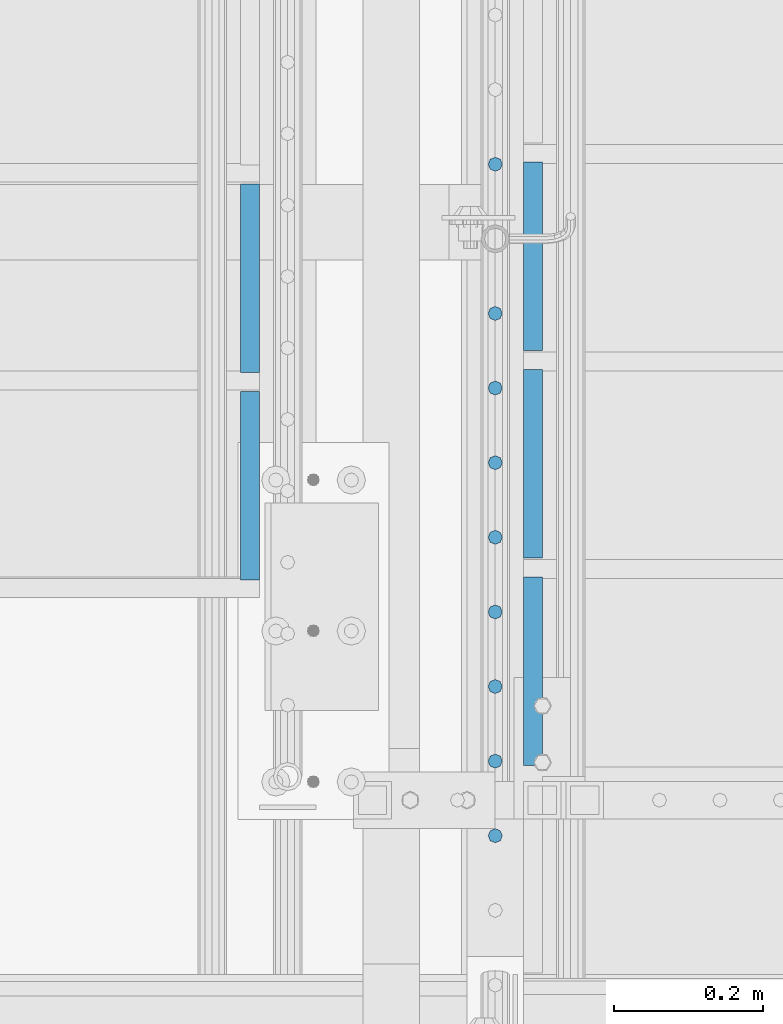
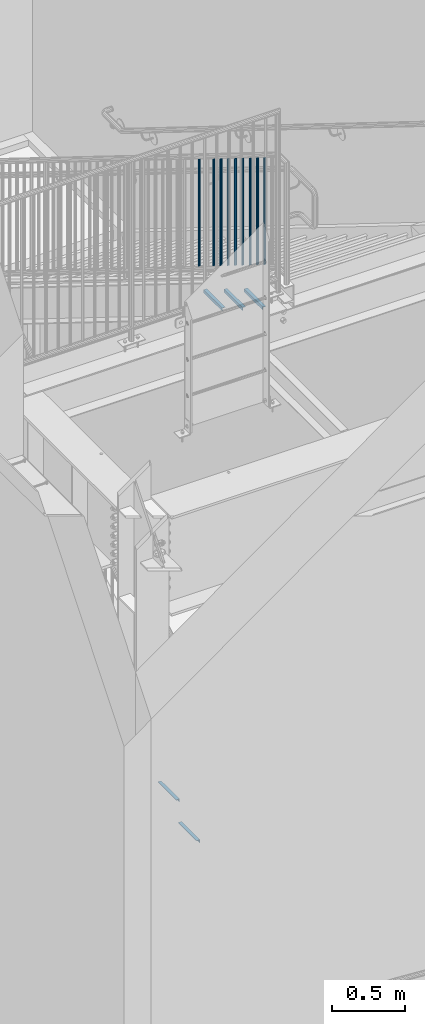
# One storey, part 1262 of 1763: 14 beams, 3 elements without a shape of their own.
"""IFC2X3 building model written with IfcOpenShell, lengths in millimetres."""

from ifc_helpers import new_model, si_unit, frame, origin_with_axes, place, context, subcontext, project, spatial, faceted_brep, material, type_object, element, aggregate, save


model = new_model("IFC2X3")

# Units and contexts
model_context = context("Model", 3, precision=1e-05, world=origin_with_axes())
body_context = subcontext(model_context, "Body", "Model", "MODEL_VIEW")
ifc_project = project(units=[si_unit("LENGTHUNIT", "METRE", prefix="MILLI"), si_unit("AREAUNIT", "SQUARE_METRE"), si_unit("VOLUMEUNIT", "CUBIC_METRE"), si_unit("MASSUNIT", "GRAM", prefix="KILO"), si_unit("TIMEUNIT", "SECOND"), si_unit("PLANEANGLEUNIT", "RADIAN"), si_unit("SOLIDANGLEUNIT", "STERADIAN"), si_unit("THERMODYNAMICTEMPERATUREUNIT", "DEGREE_CELSIUS"), si_unit("LUMINOUSINTENSITYUNIT", "LUMEN")], contexts=[model_context])

# Site, building, storey
site_placement = place(None, origin_with_axes())
site = spatial("IfcSite", under=ifc_project, at=site_placement, CompositionType="ELEMENT")
building_placement = place(site_placement, origin_with_axes())
building = spatial("IfcBuilding", under=site, at=building_placement, Name="Undefined", CompositionType="ELEMENT")
storey_placement = place(building_placement, origin_with_axes())
storey = spatial("IfcBuildingStorey", under=building, at=storey_placement, Name="Undefined", CompositionType="ELEMENT", Elevation=0.0)

# Assembly, beams
assembly_1_placement = place(storey_placement, origin_with_axes())
assembly_1 = element("IfcElementAssembly", 1, at=assembly_1_placement, inside=storey, Name="RAIL", AssemblyPlace="NOTDEFINED", PredefinedType="RIGID_FRAME")
ifc_material = material(Name="STEEL/A36")
beam_type_1 = type_object("IfcBeamType", PredefinedType="NOTDEFINED")
beam_1_placement = place(assembly_1_placement, frame((-85279.8721005486, 31975.1363633052, 6284.68158989683), z_axis=(1.0, 0.0, 0.0), x_axis=(0.0, 0.0, -1.0)))
beam_1 = element("IfcBeam", 2, at=beam_1_placement, type_object=beam_type_1, material=ifc_material, Name="PICKET", context=body_context, shape_type="Brep", body=[
    faceted_brep([(16.5092624764411, -9.52500000000146, 0.0), (18.2412682186596, -6.73519209080041, -6.73519209079677), (919.54586829654, -6.73519209080041, -6.73519209079677), (917.813862554322, -9.52500000000146, 0.0), (22.4226999716293, 0.0, -9.52499999999418), (923.727300049511, 0.0, -9.52499999999418), (26.6041317245999, 6.73519209080041, -6.73519209079677), (927.908731802481, 6.73519209080041, -6.73519209079677), (28.3361374668184, 9.52500000000146, 0.0), (929.6407375447, 9.52500000000146, 0.0), (26.6041317245999, 6.73519209080041, 6.73519209079677), (927.908731802481, 6.73519209080041, 6.73519209079677), (22.4226999716293, 0.0, 9.52499999999418), (923.727300049511, 0.0, 9.52499999999418), (18.2412682186596, -6.73519209080041, 6.73519209079677), (919.54586829654, -6.73519209080041, 6.73519209079677)], [[[0, 1, 2, 3]], [[1, 4, 5, 2]], [[4, 6, 7, 5]], [[6, 8, 9, 7]], [[8, 10, 11, 9]], [[10, 12, 13, 11]], [[12, 14, 15, 13]], [[14, 0, 3, 15]], [[5, 7, 9, 11, 13, 15, 3, 2]], [[14, 12, 10, 8, 6, 4, 1, 0]]]),
])
beam_2_placement = place(assembly_1_placement, frame((-85279.8721005486, 32075.5818178678, 6222.32170357328), z_axis=(1.0, 0.0, 0.0), x_axis=(0.0, 0.0, -1.0)))
beam_2 = element("IfcBeam", 3, at=beam_2_placement, type_object=beam_type_1, material=ifc_material, Name="PICKET", context=body_context, shape_type="Brep", body=[
    faceted_brep([(16.5092624764411, -9.52500000000146, 0.0), (18.2412682186596, -6.73519209080041, -6.73519209079677), (919.54586829654, -6.73519209080041, -6.73519209079677), (917.813862554322, -9.52500000000146, 0.0), (22.4226999716293, 0.0, -9.52499999999418), (923.727300049511, 0.0, -9.52499999999418), (26.6041317245999, 6.73519209080041, -6.73519209079677), (927.908731802481, 6.73519209080041, -6.73519209079677), (28.3361374668184, 9.52500000000146, 0.0), (929.6407375447, 9.52500000000146, 0.0), (26.6041317245999, 6.73519209080041, 6.73519209079677), (927.908731802481, 6.73519209080041, 6.73519209079677), (22.4226999716293, 0.0, 9.52499999999418), (923.727300049511, 0.0, 9.52499999999418), (18.2412682186596, -6.73519209080041, 6.73519209079677), (919.54586829654, -6.73519209080041, 6.73519209079677)], [[[0, 1, 2, 3]], [[1, 4, 5, 2]], [[4, 6, 7, 5]], [[6, 8, 9, 7]], [[8, 10, 11, 9]], [[10, 12, 13, 11]], [[12, 14, 15, 13]], [[14, 0, 3, 15]], [[5, 7, 9, 11, 13, 15, 3, 2]], [[14, 12, 10, 8, 6, 4, 1, 0]]]),
])
beam_3_placement = place(assembly_1_placement, frame((-85279.8721005486, 32176.0272724304, 6159.96181724973), z_axis=(1.0, 0.0, 0.0), x_axis=(0.0, 0.0, -1.0)))
beam_3 = element("IfcBeam", 4, at=beam_3_placement, type_object=beam_type_1, material=ifc_material, Name="PICKET", context=body_context, shape_type="Brep", body=[
    faceted_brep([(16.5092624764411, -9.52500000000146, 0.0), (18.2412682186596, -6.73519209080041, -6.73519209079677), (919.54586829654, -6.73519209080041, -6.73519209079677), (917.813862554322, -9.52500000000146, 0.0), (22.4226999716293, 0.0, -9.52499999999418), (923.727300049511, 0.0, -9.52499999999418), (26.6041317245999, 6.73519209080041, -6.73519209079677), (927.908731802481, 6.73519209080041, -6.73519209079677), (28.3361374668184, 9.52500000000146, 0.0), (929.6407375447, 9.52500000000146, 0.0), (26.6041317245999, 6.73519209080041, 6.73519209079677), (927.908731802481, 6.73519209080041, 6.73519209079677), (22.4226999716293, 0.0, 9.52499999999418), (923.727300049511, 0.0, 9.52499999999418), (18.2412682186596, -6.73519209080041, 6.73519209079677), (919.54586829654, -6.73519209080041, 6.73519209079677)], [[[0, 1, 2, 3]], [[1, 4, 5, 2]], [[4, 6, 7, 5]], [[6, 8, 9, 7]], [[8, 10, 11, 9]], [[10, 12, 13, 11]], [[12, 14, 15, 13]], [[14, 0, 3, 15]], [[5, 7, 9, 11, 13, 15, 3, 2]], [[14, 12, 10, 8, 6, 4, 1, 0]]]),
])
beam_4_placement = place(assembly_1_placement, frame((-85279.8721005486, 32276.4727269931, 6097.60193092619), z_axis=(1.0, 0.0, 0.0), x_axis=(0.0, 0.0, -1.0)))
beam_4 = element("IfcBeam", 5, at=beam_4_placement, type_object=beam_type_1, material=ifc_material, Name="PICKET", context=body_context, shape_type="Brep", body=[
    faceted_brep([(16.5092624764411, -9.52500000000146, 0.0), (18.2412682186596, -6.73519209080041, -6.73519209079677), (919.54586829654, -6.73519209080041, -6.73519209079677), (917.813862554322, -9.52500000000146, 0.0), (22.4226999716293, 0.0, -9.52499999999418), (923.727300049511, 0.0, -9.52499999999418), (26.6041317245999, 6.73519209080041, -6.73519209079677), (927.908731802481, 6.73519209080041, -6.73519209079677), (28.3361374668184, 9.52500000000146, 0.0), (929.6407375447, 9.52500000000146, 0.0), (26.6041317245999, 6.73519209080041, 6.73519209079677), (927.908731802481, 6.73519209080041, 6.73519209079677), (22.4226999716293, 0.0, 9.52499999999418), (923.727300049511, 0.0, 9.52499999999418), (18.2412682186596, -6.73519209080041, 6.73519209079677), (919.54586829654, -6.73519209080041, 6.73519209079677)], [[[0, 1, 2, 3]], [[1, 4, 5, 2]], [[4, 6, 7, 5]], [[6, 8, 9, 7]], [[8, 10, 11, 9]], [[10, 12, 13, 11]], [[12, 14, 15, 13]], [[14, 0, 3, 15]], [[5, 7, 9, 11, 13, 15, 3, 2]], [[14, 12, 10, 8, 6, 4, 1, 0]]]),
])
beam_5_placement = place(assembly_1_placement, frame((-85279.8721005486, 32376.9181815557, 6035.24204460264), z_axis=(1.0, 0.0, 0.0), x_axis=(0.0, 0.0, -1.0)))
beam_5 = element("IfcBeam", 6, at=beam_5_placement, type_object=beam_type_1, material=ifc_material, Name="PICKET", context=body_context, shape_type="Brep", body=[
    faceted_brep([(16.5092624764411, -9.52500000000146, 0.0), (18.2412682186596, -6.73519209080041, -6.73519209079677), (919.54586829654, -6.73519209080041, -6.73519209079677), (917.813862554322, -9.52500000000146, 0.0), (22.4226999716293, 0.0, -9.52499999999418), (923.727300049511, 0.0, -9.52499999999418), (26.6041317245999, 6.73519209080041, -6.73519209079677), (927.908731802481, 6.73519209080041, -6.73519209079677), (28.3361374668184, 9.52500000000146, 0.0), (929.6407375447, 9.52500000000146, 0.0), (26.6041317245999, 6.73519209080041, 6.73519209079677), (927.908731802481, 6.73519209080041, 6.73519209079677), (22.4226999716293, 0.0, 9.52499999999418), (923.727300049511, 0.0, 9.52499999999418), (18.2412682186596, -6.73519209080041, 6.73519209079677), (919.54586829654, -6.73519209080041, 6.73519209079677)], [[[0, 1, 2, 3]], [[1, 4, 5, 2]], [[4, 6, 7, 5]], [[6, 8, 9, 7]], [[8, 10, 11, 9]], [[10, 12, 13, 11]], [[12, 14, 15, 13]], [[14, 0, 3, 15]], [[5, 7, 9, 11, 13, 15, 3, 2]], [[14, 12, 10, 8, 6, 4, 1, 0]]]),
])
beam_6_placement = place(assembly_1_placement, frame((-85279.8721005486, 32477.3636361183, 5972.88215827909), z_axis=(1.0, 0.0, 0.0), x_axis=(0.0, 0.0, -1.0)))
beam_6 = element("IfcBeam", 7, at=beam_6_placement, type_object=beam_type_1, material=ifc_material, Name="PICKET", context=body_context, shape_type="Brep", body=[
    faceted_brep([(16.5092624764411, -9.52500000000146, 0.0), (18.2412682186596, -6.73519209080041, -6.73519209079677), (919.54586829654, -6.73519209080041, -6.73519209079677), (917.813862554322, -9.52500000000146, 0.0), (22.4226999716293, 0.0, -9.52499999999418), (923.727300049511, 0.0, -9.52499999999418), (26.6041317245999, 6.73519209080041, -6.73519209079677), (927.908731802481, 6.73519209080041, -6.73519209079677), (28.3361374668184, 9.52500000000146, 0.0), (929.6407375447, 9.52500000000146, 0.0), (26.6041317245999, 6.73519209080041, 6.73519209079677), (927.908731802481, 6.73519209080041, 6.73519209079677), (22.4226999716293, 0.0, 9.52499999999418), (923.727300049511, 0.0, 9.52499999999418), (18.2412682186596, -6.73519209080041, 6.73519209079677), (919.54586829654, -6.73519209080041, 6.73519209079677)], [[[0, 1, 2, 3]], [[1, 4, 5, 2]], [[4, 6, 7, 5]], [[6, 8, 9, 7]], [[8, 10, 11, 9]], [[10, 12, 13, 11]], [[12, 14, 15, 13]], [[14, 0, 3, 15]], [[5, 7, 9, 11, 13, 15, 3, 2]], [[14, 12, 10, 8, 6, 4, 1, 0]]]),
])
beam_7_placement = place(assembly_1_placement, frame((-85279.8721005486, 32577.8090906809, 5910.52227195554), z_axis=(1.0, 0.0, 0.0), x_axis=(0.0, 0.0, -1.0)))
beam_7 = element("IfcBeam", 8, at=beam_7_placement, type_object=beam_type_1, material=ifc_material, Name="PICKET", context=body_context, shape_type="Brep", body=[
    faceted_brep([(16.5092624764411, -9.52500000000146, 0.0), (18.2412682186596, -6.73519209080041, -6.73519209079677), (919.54586829654, -6.73519209080041, -6.73519209079677), (917.813862554322, -9.52500000000146, 0.0), (22.4226999716293, 0.0, -9.52499999999418), (923.727300049511, 0.0, -9.52499999999418), (26.6041317245999, 6.73519209080041, -6.73519209079677), (927.908731802481, 6.73519209080041, -6.73519209079677), (28.3361374668184, 9.52500000000146, 0.0), (929.6407375447, 9.52500000000146, 0.0), (26.6041317245999, 6.73519209080041, 6.73519209079677), (927.908731802481, 6.73519209080041, 6.73519209079677), (22.4226999716293, 0.0, 9.52499999999418), (923.727300049511, 0.0, 9.52499999999418), (18.2412682186596, -6.73519209080041, 6.73519209079677), (919.54586829654, -6.73519209080041, 6.73519209079677)], [[[0, 1, 2, 3]], [[1, 4, 5, 2]], [[4, 6, 7, 5]], [[6, 8, 9, 7]], [[8, 10, 11, 9]], [[10, 12, 13, 11]], [[12, 14, 15, 13]], [[14, 0, 3, 15]], [[5, 7, 9, 11, 13, 15, 3, 2]], [[14, 12, 10, 8, 6, 4, 1, 0]]]),
])
beam_8_placement = place(assembly_1_placement, frame((-85279.8721005486, 32678.2545452435, 5848.16238563199), z_axis=(1.0, 0.0, 0.0), x_axis=(0.0, 0.0, -1.0)))
beam_8 = element("IfcBeam", 9, at=beam_8_placement, type_object=beam_type_1, material=ifc_material, Name="PICKET", context=body_context, shape_type="Brep", body=[
    faceted_brep([(16.5092624764411, -9.52500000000146, 0.0), (18.2412682186596, -6.73519209080041, -6.73519209079677), (919.54586829654, -6.73519209080041, -6.73519209079677), (917.813862554322, -9.52500000000146, 0.0), (22.4226999716293, 0.0, -9.52499999999418), (923.727300049511, 0.0, -9.52499999999418), (26.6041317245999, 6.73519209080041, -6.73519209079677), (927.908731802481, 6.73519209080041, -6.73519209079677), (28.3361374668184, 9.52500000000146, 0.0), (929.6407375447, 9.52500000000146, 0.0), (26.6041317245999, 6.73519209080041, 6.73519209079677), (927.908731802481, 6.73519209080041, 6.73519209079677), (22.4226999716293, 0.0, 9.52499999999418), (923.727300049511, 0.0, 9.52499999999418), (18.2412682186596, -6.73519209080041, 6.73519209079677), (919.54586829654, -6.73519209080041, 6.73519209079677)], [[[0, 1, 2, 3]], [[1, 4, 5, 2]], [[4, 6, 7, 5]], [[6, 8, 9, 7]], [[8, 10, 11, 9]], [[10, 12, 13, 11]], [[12, 14, 15, 13]], [[14, 0, 3, 15]], [[5, 7, 9, 11, 13, 15, 3, 2]], [[14, 12, 10, 8, 6, 4, 1, 0]]]),
])
beam_9_placement = place(assembly_1_placement, frame((-85279.8721005486, 32879.1454543687, 5723.4426129849), z_axis=(1.0, 0.0, 0.0), x_axis=(0.0, 0.0, -1.0)))
beam_9 = element("IfcBeam", 10, at=beam_9_placement, type_object=beam_type_1, material=ifc_material, Name="PICKET", context=body_context, shape_type="Brep", body=[
    faceted_brep([(16.5092624764411, -9.52500000000146, 0.0), (18.2412682186596, -6.73519209080041, -6.73519209079677), (919.54586829654, -6.73519209080041, -6.73519209079677), (917.813862554322, -9.52500000000146, 0.0), (22.4226999716293, 0.0, -9.52499999999418), (923.727300049511, 0.0, -9.52499999999418), (26.6041317245999, 6.73519209080041, -6.73519209079677), (927.908731802481, 6.73519209080041, -6.73519209079677), (28.3361374668184, 9.52500000000146, 0.0), (929.6407375447, 9.52500000000146, 0.0), (26.6041317245999, 6.73519209080041, 6.73519209079677), (927.908731802481, 6.73519209080041, 6.73519209079677), (22.4226999716293, 0.0, 9.52499999999418), (923.727300049511, 0.0, 9.52499999999418), (18.2412682186596, -6.73519209080041, 6.73519209079677), (919.54586829654, -6.73519209080041, 6.73519209079677)], [[[0, 1, 2, 3]], [[1, 4, 5, 2]], [[4, 6, 7, 5]], [[6, 8, 9, 7]], [[8, 10, 11, 9]], [[10, 12, 13, 11]], [[12, 14, 15, 13]], [[14, 0, 3, 15]], [[5, 7, 9, 11, 13, 15, 3, 2]], [[14, 12, 10, 8, 6, 4, 1, 0]]]),
])
aggregate(assembly_1, [beam_1, beam_2, beam_3, beam_4, beam_5, beam_6, beam_7, beam_8, beam_9])

assembly_2_placement = place(storey_placement, origin_with_axes())
assembly_2 = element("IfcElementAssembly", 11, at=assembly_2_placement, inside=storey, Name="STRINGER", AssemblyPlace="NOTDEFINED", PredefinedType="RIGID_FRAME")
beam_type_2 = type_object("IfcBeamType", Name="L1X1X1/8", PredefinedType="NOTDEFINED")
beam_10_placement = place(assembly_2_placement, frame((-85229.072101503, 32069.5524594165, 4920.40333353658), z_axis=(1.0, 0.0, 0.0), x_axis=(0.0, 1.0, 0.0)))
beam_10 = element("IfcBeam", 12, at=beam_10_placement, type_object=beam_type_2, material=ifc_material, Name="ANGLE", ObjectType="L1X1X1/8", context=body_context, shape_type="Brep", body=[
    faceted_brep([(3.93434019839663e-12, 12.6999999999978, -12.6999998092651), (-1.31614667686587e-12, 12.6999999999978, 12.6999998092651), (254.0, 12.69999981, 12.6999998099927), (254.0, 12.69999981, -12.6999998099927), (-1.06936913171421e-12, 9.52499999999854, 12.699999332428), (254.0, 9.52499985799977, 12.6999998099927), (0.0, 9.52499985799977, -9.52499985799659), (254.0, 9.52499985799977, -9.52499985799659), (0.0, -12.69999981, -9.52499985799659), (254.0, -12.69999981, -9.52499985799659), (0.0, -12.69999981, -12.6999998099927), (254.0, -12.69999981, -12.6999998099927)], [[[0, 1, 2, 3]], [[1, 4, 5, 2]], [[4, 6, 7, 5]], [[6, 8, 9, 7]], [[8, 10, 11, 9]], [[10, 0, 3, 11]], [[5, 7, 9, 11, 3, 2]], [[10, 8, 6, 4, 1, 0]]]),
])
beam_11_placement = place(assembly_2_placement, frame((-85229.072101503, 32348.9524595004, 4746.94250020325), z_axis=(1.0, 0.0, 0.0), x_axis=(0.0, 1.0, 0.0)))
beam_11 = element("IfcBeam", 13, at=beam_11_placement, type_object=beam_type_2, material=ifc_material, Name="ANGLE", ObjectType="L1X1X1/8", context=body_context, shape_type="Brep", body=[
    faceted_brep([(3.93434019839663e-12, 12.6999999999978, -12.6999998092651), (-1.31614667686587e-12, 12.6999999999978, 12.6999998092651), (254.0, 12.69999981, 12.6999998099927), (254.0, 12.69999981, -12.6999998099927), (-1.06936913171421e-12, 9.52499999999854, 12.699999332428), (254.0, 9.52499985799977, 12.6999998099927), (0.0, 9.52499985799977, -9.52499985799659), (254.0, 9.52499985799977, -9.52499985799659), (0.0, -12.69999981, -9.52499985799659), (254.0, -12.69999981, -9.52499985799659), (0.0, -12.69999981, -12.6999998099927), (254.0, -12.69999981, -12.6999998099927)], [[[0, 1, 2, 3]], [[1, 4, 5, 2]], [[4, 6, 7, 5]], [[6, 8, 9, 7]], [[8, 10, 11, 9]], [[10, 0, 3, 11]], [[5, 7, 9, 11, 3, 2]], [[10, 8, 6, 4, 1, 0]]]),
])
beam_12_placement = place(assembly_2_placement, frame((-85229.072101503, 32628.3524595843, 4573.48166686991), z_axis=(1.0, 0.0, 0.0), x_axis=(0.0, 1.0, 0.0)))
beam_12 = element("IfcBeam", 14, at=beam_12_placement, type_object=beam_type_2, material=ifc_material, Name="ANGLE", ObjectType="L1X1X1/8", context=body_context, shape_type="Brep", body=[
    faceted_brep([(3.93434019839663e-12, 12.6999999999978, -12.6999998092651), (-1.31614667686587e-12, 12.6999999999978, 12.6999998092651), (254.0, 12.69999981, 12.6999998099927), (254.0, 12.69999981, -12.6999998099927), (-1.06936913171421e-12, 9.52499999999854, 12.699999332428), (254.0, 9.52499985799977, 12.6999998099927), (0.0, 9.52499985799977, -9.52499985799659), (254.0, 9.52499985799977, -9.52499985799659), (0.0, -12.69999981, -9.52499985799659), (254.0, -12.69999981, -9.52499985799659), (0.0, -12.69999981, -12.6999998099927), (254.0, -12.69999981, -12.6999998099927)], [[[0, 1, 2, 3]], [[1, 4, 5, 2]], [[4, 6, 7, 5]], [[6, 8, 9, 7]], [[8, 10, 11, 9]], [[10, 0, 3, 11]], [[5, 7, 9, 11, 3, 2]], [[10, 8, 6, 4, 1, 0]]]),
])
aggregate(assembly_2, [beam_10, beam_11, beam_12])

assembly_3_placement = place(storey_placement, origin_with_axes())
assembly_3 = element("IfcElementAssembly", 15, at=assembly_3_placement, inside=storey, Name="STRINGER", AssemblyPlace="NOTDEFINED", PredefinedType="RIGID_FRAME")
beam_13_placement = place(assembly_3_placement, frame((-85610.137273544, 32852.8511407179, 584.880357333434), z_axis=(-1.0, 0.0, 0.0), x_axis=(0.0, -1.0, 0.0)))
beam_13 = element("IfcBeam", 16, at=beam_13_placement, type_object=beam_type_2, material=ifc_material, Name="ANGLE", ObjectType="L1X1X1/8", context=body_context, shape_type="Brep", body=[
    faceted_brep([(3.93434019839663e-12, 12.6999999999978, -12.6999998092651), (-1.31614667686587e-12, 12.6999999999978, 12.6999998092651), (254.0, 12.69999981, 12.6999998099927), (254.0, 12.69999981, -12.6999998099927), (-1.06936913171421e-12, 9.52499999999854, 12.699999332428), (254.0, 9.52499985799977, 12.6999998099927), (0.0, 9.52499985799977, -9.52499985799659), (254.0, 9.52499985799977, -9.52499985799659), (0.0, -12.69999981, -9.52499985799659), (254.0, -12.69999981, -9.52499985799659), (0.0, -12.69999981, -12.6999998099927), (254.0, -12.69999981, -12.6999998099927)], [[[0, 1, 2, 3]], [[1, 4, 5, 2]], [[4, 6, 7, 5]], [[6, 8, 9, 7]], [[8, 10, 11, 9]], [[10, 0, 3, 11]], [[5, 7, 9, 11, 3, 2]], [[10, 8, 6, 4, 1, 0]]]),
])
beam_14_placement = place(assembly_3_placement, frame((-85610.137273544, 32573.4511407179, 411.502678762005), z_axis=(-1.0, 0.0, 0.0), x_axis=(0.0, -1.0, 0.0)))
beam_14 = element("IfcBeam", 17, at=beam_14_placement, type_object=beam_type_2, material=ifc_material, Name="ANGLE", ObjectType="L1X1X1/8", context=body_context, shape_type="Brep", body=[
    faceted_brep([(3.93434019839663e-12, 12.6999999999978, -12.6999998092651), (-1.31614667686587e-12, 12.6999999999978, 12.6999998092651), (254.0, 12.69999981, 12.6999998099927), (254.0, 12.69999981, -12.6999998099927), (-1.06936913171421e-12, 9.52499999999854, 12.699999332428), (254.0, 9.52499985799977, 12.6999998099927), (0.0, 9.52499985799977, -9.52499985799659), (254.0, 9.52499985799977, -9.52499985799659), (0.0, -12.69999981, -9.52499985799659), (254.0, -12.69999981, -9.52499985799659), (0.0, -12.69999981, -12.6999998099927), (254.0, -12.69999981, -12.6999998099927)], [[[0, 1, 2, 3]], [[1, 4, 5, 2]], [[4, 6, 7, 5]], [[6, 8, 9, 7]], [[8, 10, 11, 9]], [[10, 0, 3, 11]], [[5, 7, 9, 11, 3, 2]], [[10, 8, 6, 4, 1, 0]]]),
])
aggregate(assembly_3, [beam_13, beam_14])

save(model, "model.ifc")
